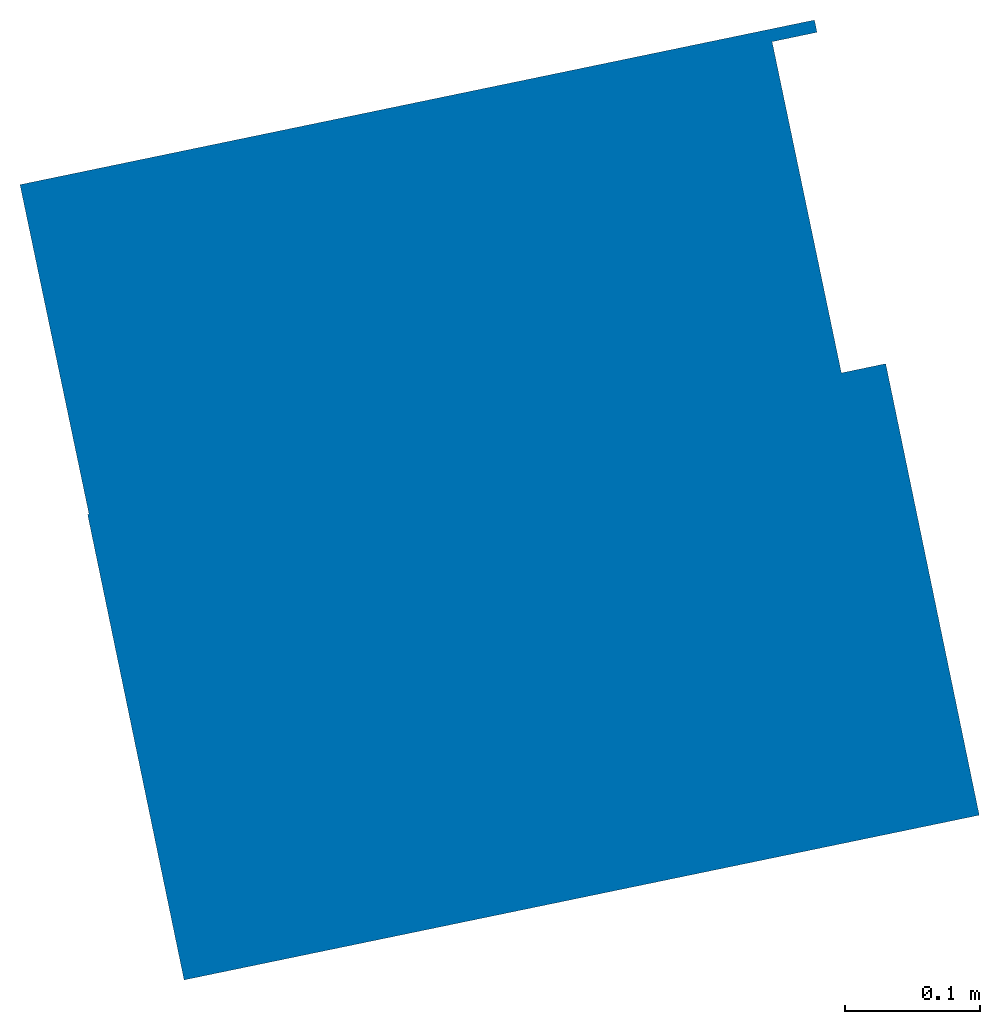
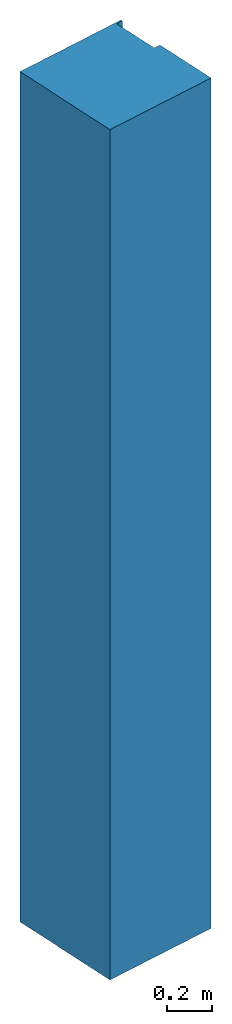
# Not in any storey: 1 column.
"""IFC2X3 model written with IfcOpenShell, lengths in metres."""

from ifc_helpers import new_model, entity, si_unit, converted_unit, derived_unit, direction, frame, frame_2d, origin, place, context, subcontext, project, polyline, circle_curve, parameter, trimmed, segment, composite_curve, outline, extrude, source, transform, mapped, element, save


model = new_model("IFC2X3")

# Units and contexts
model_context = context("Model", 3, precision=1e-05, world=origin(), true_north=direction((6.12303176911189e-17, 1.0)))
body_context = subcontext(model_context, "Body", "Model", "MODEL_VIEW")
ifc_project = project(units=[si_unit("LENGTHUNIT", "METRE"), si_unit("AREAUNIT", "SQUARE_METRE"), si_unit("VOLUMEUNIT", "CUBIC_METRE"), converted_unit("PLANEANGLEUNIT", "DEGREE", entity("IfcRatioMeasure", 0.0174532925199433), si_unit("PLANEANGLEUNIT", "RADIAN"), dimensions=[0, 0, 0, 0, 0, 0, 0]), si_unit("MASSUNIT", "GRAM", prefix="KILO"), derived_unit("MASSDENSITYUNIT", [(si_unit("MASSUNIT", "GRAM", prefix="KILO"), 1), (si_unit("LENGTHUNIT", "METRE"), -3)]), si_unit("TIMEUNIT", "SECOND"), si_unit("FREQUENCYUNIT", "HERTZ"), si_unit("THERMODYNAMICTEMPERATUREUNIT", "DEGREE_CELSIUS"), derived_unit("THERMALTRANSMITTANCEUNIT", [(si_unit("MASSUNIT", "GRAM", prefix="KILO"), 1), (si_unit("THERMODYNAMICTEMPERATUREUNIT", "KELVIN"), -1), (si_unit("TIMEUNIT", "SECOND"), -3)]), derived_unit("VOLUMETRICFLOWRATEUNIT", [(si_unit("LENGTHUNIT", "METRE"), 3), (si_unit("TIMEUNIT", "SECOND"), -1)]), si_unit("ELECTRICCURRENTUNIT", "AMPERE"), si_unit("ELECTRICVOLTAGEUNIT", "VOLT"), si_unit("POWERUNIT", "WATT"), si_unit("FORCEUNIT", "NEWTON", prefix="KILO"), si_unit("ILLUMINANCEUNIT", "LUX"), si_unit("LUMINOUSFLUXUNIT", "LUMEN"), si_unit("LUMINOUSINTENSITYUNIT", "CANDELA"), derived_unit("USERDEFINED", [(si_unit("MASSUNIT", "GRAM", prefix="KILO"), -1), (si_unit("LENGTHUNIT", "METRE"), -2), (si_unit("TIMEUNIT", "SECOND"), 3), (si_unit("LUMINOUSFLUXUNIT", "LUMEN"), 1)]), derived_unit("LINEARVELOCITYUNIT", [(si_unit("LENGTHUNIT", "METRE"), 1), (si_unit("TIMEUNIT", "SECOND"), -1)]), si_unit("PRESSUREUNIT", "PASCAL"), derived_unit("USERDEFINED", [(si_unit("LENGTHUNIT", "METRE"), -2), (si_unit("MASSUNIT", "GRAM", prefix="KILO"), 1), (si_unit("TIMEUNIT", "SECOND"), -2)])], contexts=[model_context])

# Column
shared_shape = source(origin(), body_context, "Body", "SweptSolid", [
    extrude(outline(composite_curve([segment(polyline([(-0.376512856626643, -0.246574632694432), (-0.0358223022994915, -0.246574632694432)]), True, "CONTINUOUS"), segment(trimmed(circle_curve(frame_2d((-104.746282641127, -0.414809627556991), x_axis=(0.999643942920116, -0.0266830917085281)), 104.710595487671), [parameter(1.62106525824569)], [parameter(1.63936099520168)], True, "PARAMETER"), True, "CONTINUOUS"), segment(polyline([(-0.0358813616830793, -0.213138408749268), (0.214118174638392, -0.212656912064088)]), True, "CONTINUOUS"), segment(trimmed(circle_curve(frame_2d((-104.746282641127, -0.414809627556991), x_axis=(0.999643942920116, -0.0266830917085281)), 104.960595487671), [parameter(1.62084599662285)], [parameter(1.63936099520133)], True, "PARAMETER"), False, "CONTINUOUS"), segment(polyline([(0.214178019604691, -0.246574632694432), (0.223487143373357, -0.246574632694432)]), True, "CONTINUOUS"), segment(polyline([(0.223487143373357, -0.246574632694432), (0.223487143373355, 0.352886710408896)]), True, "CONTINUOUS"), segment(polyline([(0.223487143373355, 0.352886710408895), (-0.0252694100220232, 0.352356406571777)]), True, "CONTINUOUS"), segment(trimmed(circle_curve(frame_2d((-117.113637220702, 0.102745250715724), x_axis=(0.999890837861553, 0.0147753971356757)), 117.088633873226), [parameter(359.275545319002)], [parameter(359.27606840204)], True, "PARAMETER"), True, "CONTINUOUS"), segment(polyline([(-0.0252716937319421, 0.353425367305567), (-0.37651285662664, 0.353425367305568)]), True, "CONTINUOUS"), segment(polyline([(-0.37651285662664, 0.353425367305568), (-0.376512856626643, -0.246574632694432)]), True, "CONTINUOUS")], self_intersect=False)), frame((1.94405696596406, -21.2996597075785, -0.599997891152076), z_axis=(0.0, 0.0, 1.0), x_axis=(-0.202929626136137, 0.979193324546408, 0.0)), (0.0, 0.0, 1.0), 4.59999789115173),
])
placement_1 = place(None, origin())
placement_2 = place(placement_1, origin())
placement_3 = place(placement_2, frame((0.0, 0.0, -2.79999789115208)))
column_placement = place(placement_3, frame((0.0, 0.0, 2.79999789115208)))
element("IfcColumn", 1, at=column_placement, ObjectType="60 x 60", context=body_context, shape_type="MappedRepresentation", body=[
    mapped(shared_shape, transform((0.0, 0.0, 0.0), scale=1.0)),
])

save(model, "model.ifc")
